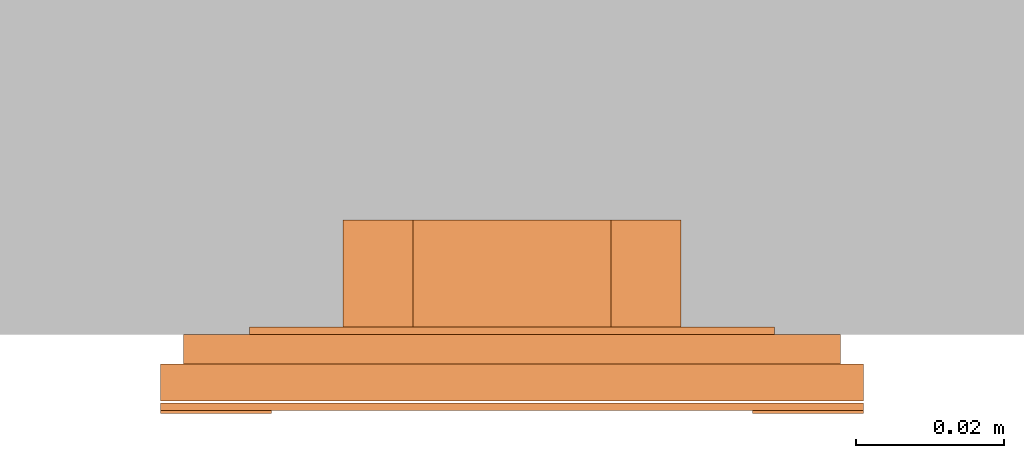
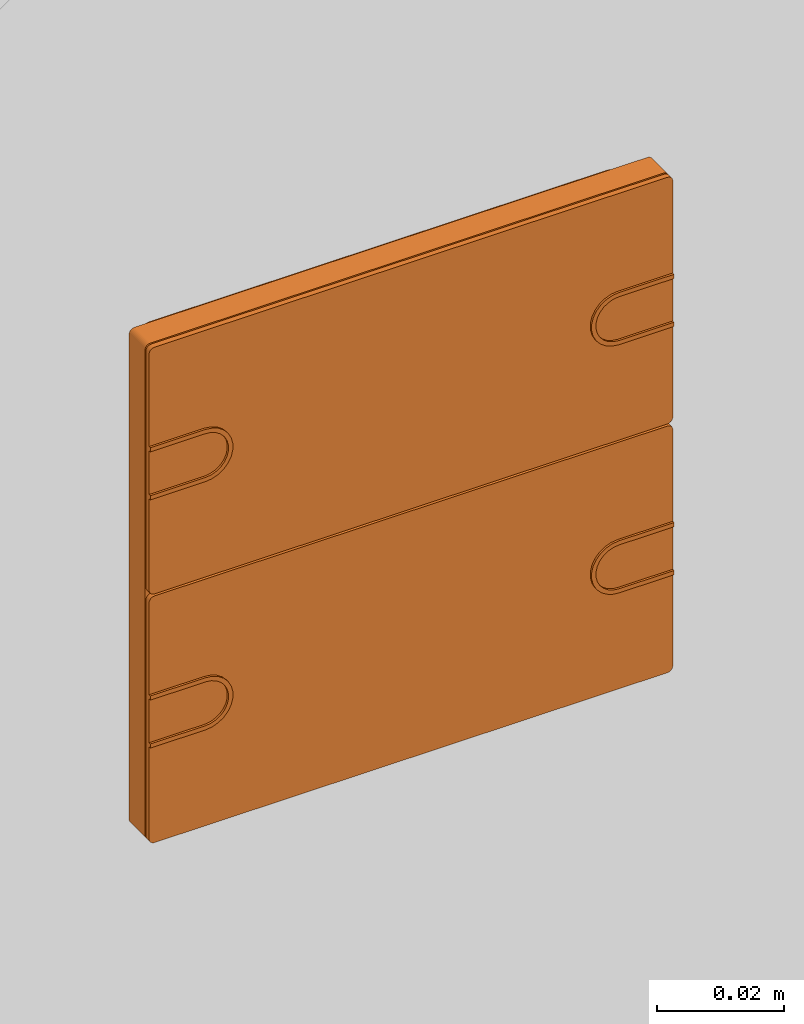
# One storey, part 2 of 2: 1 proxy.
"""IFC2X3 building model written with IfcOpenShell, lengths in metres."""

from ifc_helpers import new_model, entity, si_unit, converted_unit, derived_unit, direction, frame, frame_2d, origin, place, context, subcontext, project, spatial, polyline, circle_curve, parameter, trimmed, segment, composite_curve, outline, extrude, source, transform, mapped, material, type_object, type_shapes, element, save


model = new_model("IFC2X3")

# Units and contexts
model_context = context("Model", 3, precision=1e-05, world=origin(), true_north=direction((6.12303176911189e-17, 1.0)))
body_context = subcontext(model_context, "Body", "Model", "MODEL_VIEW")
ifc_project = project(units=[si_unit("LENGTHUNIT", "METRE"), si_unit("AREAUNIT", "SQUARE_METRE"), si_unit("VOLUMEUNIT", "CUBIC_METRE"), converted_unit("PLANEANGLEUNIT", "DEGREE", entity("IfcRatioMeasure", 0.0174532925199433), si_unit("PLANEANGLEUNIT", "RADIAN"), dimensions=[0, 0, 0, 0, 0, 0, 0]), si_unit("MASSUNIT", "GRAM", prefix="KILO"), si_unit("TIMEUNIT", "SECOND"), si_unit("FREQUENCYUNIT", "HERTZ"), si_unit("THERMODYNAMICTEMPERATUREUNIT", "DEGREE_CELSIUS"), derived_unit("THERMALTRANSMITTANCEUNIT", [(si_unit("MASSUNIT", "GRAM", prefix="KILO"), 1), (si_unit("THERMODYNAMICTEMPERATUREUNIT", "KELVIN"), -1), (si_unit("TIMEUNIT", "SECOND"), -3)]), derived_unit("VOLUMETRICFLOWRATEUNIT", [(si_unit("LENGTHUNIT", "METRE"), 3), (si_unit("TIMEUNIT", "SECOND"), -1)]), si_unit("ELECTRICCURRENTUNIT", "AMPERE"), si_unit("ELECTRICVOLTAGEUNIT", "VOLT"), si_unit("POWERUNIT", "WATT"), si_unit("FORCEUNIT", "NEWTON", prefix="KILO"), si_unit("ILLUMINANCEUNIT", "LUX"), si_unit("LUMINOUSFLUXUNIT", "LUMEN"), si_unit("LUMINOUSINTENSITYUNIT", "CANDELA"), derived_unit("USERDEFINED", [(si_unit("MASSUNIT", "GRAM", prefix="KILO"), -1), (si_unit("LENGTHUNIT", "METRE"), -2), (si_unit("TIMEUNIT", "SECOND"), 3), (si_unit("LUMINOUSFLUXUNIT", "LUMEN"), 1)]), derived_unit("LINEARVELOCITYUNIT", [(si_unit("LENGTHUNIT", "METRE"), 1), (si_unit("TIMEUNIT", "SECOND"), -1)]), si_unit("PRESSUREUNIT", "PASCAL"), derived_unit("USERDEFINED", [(si_unit("LENGTHUNIT", "METRE"), -2), (si_unit("MASSUNIT", "GRAM", prefix="KILO"), 1), (si_unit("TIMEUNIT", "SECOND"), -2)])], contexts=[model_context])

# Site, building, storey
site_placement = place(None, origin())
site = spatial("IfcSite", under=ifc_project, at=site_placement, CompositionType="ELEMENT")
building_placement = place(site_placement, origin())
building = spatial("IfcBuilding", under=site, at=building_placement, CompositionType="ELEMENT")
storey_placement = place(building_placement, origin())
storey = spatial("IfcBuildingStorey", under=building, at=storey_placement, Name="Ebene 0", CompositionType="ELEMENT", Elevation=0.0)

# Proxy
ifc_material = material(Name="White")
building_element_proxy_type = type_object("IfcBuildingElementProxyType", PredefinedType="NOTDEFINED", material=ifc_material)
shared_shape = source(origin(), body_context, "Body", "SweptSolid", [
    extrude(outline(composite_curve([segment(polyline([(-0.00499999999999999, -0.00499999999999998), (-0.0042, -0.00499999999999998)]), True, "CONTINUOUS"), segment(polyline([(-0.0042, -0.00499999999999998), (-0.00420000000000001, 0.00499999999999998)]), True, "CONTINUOUS"), segment(trimmed(circle_curve(frame_2d((0.0, 0.005), x_axis=(0.0, 1.0)), 0.00420000000000002), [parameter(270.0)], [parameter(90.0000000000005)], True, "PARAMETER"), False, "CONTINUOUS"), segment(polyline([(0.00420000000000002, 0.00500000000000003), (0.00420000000000001, -0.00499999999999998)]), True, "CONTINUOUS"), segment(polyline([(0.00420000000000001, -0.00499999999999998), (0.005, -0.00499999999999998)]), True, "CONTINUOUS"), segment(polyline([(0.005, -0.00499999999999998), (0.00500000000000001, 0.00500000000000003)]), True, "CONTINUOUS"), segment(trimmed(circle_curve(frame_2d((0.0, 0.005), x_axis=(0.0, 1.0)), 0.00500000000000001), [parameter(270.0)], [parameter(90.0000000000002)], True, "PARAMETER"), True, "CONTINUOUS"), segment(polyline([(-0.00500000000000002, 0.00499999999999998), (-0.00499999999999999, -0.00499999999999998)]), True, "CONTINUOUS")], self_intersect=False)), frame((-0.0424999999999937, 0.0237999992370521, 0.00949999999999813), z_axis=(0.0, 0.0, 1.0), x_axis=(0.0, -1.0, 0.0)), (0.0, 0.0, 1.0), 0.0012),
    extrude(outline(composite_curve([segment(polyline([(-0.00499999999999996, -0.00500000000000001), (0.005, -0.00500000000000001)]), True, "CONTINUOUS"), segment(trimmed(circle_curve(frame_2d((0.005, 0.0), x_axis=(1.0, 0.0)), 0.00500000000000001), [parameter(269.999999999999)], [parameter(89.9999999999998)], True, "PARAMETER"), True, "CONTINUOUS"), segment(polyline([(0.00500000000000002, 0.00500000000000002), (-0.00499999999999998, 0.00499999999999999)]), True, "CONTINUOUS"), segment(polyline([(-0.00499999999999998, 0.00499999999999999), (-0.00499999999999998, 0.0042)]), True, "CONTINUOUS"), segment(polyline([(-0.00499999999999998, 0.00419999999999999), (0.00500000000000003, 0.00420000000000003)]), True, "CONTINUOUS"), segment(trimmed(circle_curve(frame_2d((0.00500000000000001, 0.0), x_axis=(1.0, 0.0)), 0.00420000000000002), [parameter(270.0)], [parameter(90.0000000000002)], True, "PARAMETER"), False, "CONTINUOUS"), segment(polyline([(0.00499999999999999, -0.0042), (-0.00499999999999996, -0.00420000000000001)]), True, "CONTINUOUS"), segment(polyline([(-0.00499999999999996, -0.00420000000000001), (-0.00499999999999996, -0.00500000000000001)]), True, "CONTINUOUS")], self_intersect=False)), frame((-0.0424999999999937, -0.0237999992370689, 0.00949999999999813)), (0.0, 0.0, 1.0), 0.0012),
    extrude(outline(composite_curve([segment(polyline([(-0.00499999999999996, -0.005), (0.005, -0.00500000000000001)]), True, "CONTINUOUS"), segment(trimmed(circle_curve(frame_2d((0.005, 0.0), x_axis=(1.0, 0.0)), 0.00500000000000001), [parameter(269.999999999999)], [parameter(89.9999999999998)], True, "PARAMETER"), True, "CONTINUOUS"), segment(polyline([(0.00500000000000001, 0.00500000000000002), (-0.00499999999999998, 0.00499999999999998)]), True, "CONTINUOUS"), segment(polyline([(-0.00499999999999998, 0.00499999999999998), (-0.00499999999999998, 0.0042)]), True, "CONTINUOUS"), segment(polyline([(-0.00499999999999998, 0.00419999999999999), (0.00500000000000001, 0.00420000000000004)]), True, "CONTINUOUS"), segment(trimmed(circle_curve(frame_2d((0.00500000000000001, 0.0), x_axis=(1.0, 0.0)), 0.00420000000000002), [parameter(270.0)], [parameter(90.0000000000003)], True, "PARAMETER"), False, "CONTINUOUS"), segment(polyline([(0.00499999999999999, -0.0042), (-0.00499999999999996, -0.00420000000000001)]), True, "CONTINUOUS"), segment(polyline([(-0.00499999999999996, -0.00420000000000001), (-0.00499999999999996, -0.005)]), True, "CONTINUOUS")], self_intersect=False)), frame((0.0425000000000063, 0.0237999992370521, 0.00949999999999813), z_axis=(0.0, 0.0, 1.0), x_axis=(-1.0, 0.0, 0.0)), (0.0, 0.0, 1.0), 0.0012),
    extrude(outline(composite_curve([segment(polyline([(-0.005, -0.00499999999999998), (-0.0042, -0.00499999999999998)]), True, "CONTINUOUS"), segment(polyline([(-0.0042, -0.00499999999999998), (-0.00420000000000002, 0.00499999999999996)]), True, "CONTINUOUS"), segment(trimmed(circle_curve(frame_2d((0.0, 0.005), x_axis=(0.0, 1.0)), 0.00420000000000002), [parameter(270.0)], [parameter(90.0000000000005)], True, "PARAMETER"), False, "CONTINUOUS"), segment(polyline([(0.00420000000000002, 0.00500000000000001), (0.0042, -0.00499999999999998)]), True, "CONTINUOUS"), segment(polyline([(0.00420000000000001, -0.00499999999999998), (0.005, -0.00499999999999998)]), True, "CONTINUOUS"), segment(polyline([(0.005, -0.00499999999999998), (0.005, 0.00500000000000001)]), True, "CONTINUOUS"), segment(trimmed(circle_curve(frame_2d((0.0, 0.00499999999999998), x_axis=(0.0, 1.0)), 0.00500000000000001), [parameter(270.0)], [parameter(90.0000000000002)], True, "PARAMETER"), True, "CONTINUOUS"), segment(polyline([(-0.00500000000000002, 0.00499999999999998), (-0.005, -0.00499999999999998)]), True, "CONTINUOUS")], self_intersect=False)), frame((0.0425000000000063, -0.0237999992370689, 0.00949999999999813), z_axis=(0.0, 0.0, 1.0), x_axis=(0.0, 1.0, 0.0)), (0.0, 0.0, 1.0), 0.0012),
    extrude(outline(composite_curve([segment(trimmed(circle_curve(frame_2d((0.0465000000000126, 0.0226500000000084), x_axis=(1.0, 0.0)), 0.001), [parameter(0.0)], [parameter(90.0000000000001)], True, "PARAMETER"), True, "CONTINUOUS"), segment(polyline([(0.0465000000000126, 0.0236500000000084), (-0.0465000000000126, 0.0236500000000084)]), True, "CONTINUOUS"), segment(trimmed(circle_curve(frame_2d((-0.0465000000000126, 0.0226500000000084), x_axis=(1.0, 0.0)), 0.001), [parameter(90.0000000000011)], [parameter(179.999999999999)], True, "PARAMETER"), True, "CONTINUOUS"), segment(polyline([(-0.0475000000000126, 0.0226500000000085), (-0.0475000000000126, -0.0226500000000084)]), True, "CONTINUOUS"), segment(trimmed(circle_curve(frame_2d((-0.0465000000000126, -0.0226500000000084), x_axis=(1.0, 0.0)), 0.001), [parameter(180.0)], [parameter(269.999999999999)], True, "PARAMETER"), True, "CONTINUOUS"), segment(polyline([(-0.0465000000000126, -0.0236500000000084), (0.0465000000000126, -0.0236500000000084)]), True, "CONTINUOUS"), segment(trimmed(circle_curve(frame_2d((0.0465000000000125, -0.0226500000000084), x_axis=(1.0, 0.0)), 0.001), [parameter(269.999999999999)], [parameter(359.999999999999)], True, "PARAMETER"), True, "CONTINUOUS"), segment(polyline([(0.0475000000000125, -0.0226500000000084), (0.0475000000000127, 0.0226500000000085)]), True, "CONTINUOUS")], self_intersect=False)), frame((0.0, 0.0238499999999831, 0.00929999999999813)), (0.0, 0.0, 1.0), 0.001),
    extrude(outline(composite_curve([segment(trimmed(circle_curve(frame_2d((-0.0465000000000125, 0.0226500000000083), x_axis=(1.0, 0.0)), 0.001), [parameter(90.0000000000003)], [parameter(180.0)], True, "PARAMETER"), True, "CONTINUOUS"), segment(polyline([(-0.0475000000000125, 0.0226500000000083), (-0.0475000000000125, -0.0226500000000085)]), True, "CONTINUOUS"), segment(trimmed(circle_curve(frame_2d((-0.0465000000000125, -0.0226500000000085), x_axis=(-1.0, 0.0)), 0.001), [parameter(2.54444374517082e-13)], [parameter(90.0000000000001)], True, "PARAMETER"), True, "CONTINUOUS"), segment(polyline([(-0.0465000000000125, -0.0236500000000085), (0.0465000000000126, -0.0236500000000082)]), True, "CONTINUOUS"), segment(trimmed(circle_curve(frame_2d((0.0465000000000126, -0.0226500000000082), x_axis=(-1.0, 0.0)), 0.001), [parameter(90.0000000000001)], [parameter(180.0)], True, "PARAMETER"), True, "CONTINUOUS"), segment(polyline([(0.0475000000000126, -0.0226500000000082), (0.0475000000000124, 0.0226500000000083)]), True, "CONTINUOUS"), segment(trimmed(circle_curve(frame_2d((0.0465000000000124, 0.0226500000000083), x_axis=(-1.0, 0.0)), 0.001), [parameter(180.0)], [parameter(269.999999999999)], True, "PARAMETER"), True, "CONTINUOUS"), segment(polyline([(0.0465000000000125, 0.0236500000000083), (-0.0465000000000125, 0.0236500000000083)]), True, "CONTINUOUS")], self_intersect=False)), frame((0.0, -0.0238500000000336, 0.00929999999999813), z_axis=(0.0, 0.0, 1.0), x_axis=(-1.0, 0.0, 0.0)), (0.0, 0.0, 1.0), 0.001),
    extrude(outline(composite_curve([segment(trimmed(circle_curve(frame_2d((-0.0465000000000125, 0.0465000000000168), x_axis=(1.0, 0.0)), 0.001), [parameter(90.0000000000003)], [parameter(180.0)], True, "PARAMETER"), True, "CONTINUOUS"), segment(polyline([(-0.0475000000000125, 0.0465000000000168), (-0.0475000000000125, -0.0465000000000169)]), True, "CONTINUOUS"), segment(trimmed(circle_curve(frame_2d((-0.0465000000000125, -0.0465000000000169), x_axis=(-1.0, 0.0)), 0.001), [parameter(0.0)], [parameter(90.0000000000001)], True, "PARAMETER"), True, "CONTINUOUS"), segment(polyline([(-0.0465000000000125, -0.0475000000000169), (0.0465000000000127, -0.0475000000000166)]), True, "CONTINUOUS"), segment(trimmed(circle_curve(frame_2d((0.0465000000000127, -0.0465000000000166), x_axis=(-1.0, 0.0)), 0.001), [parameter(90.0000000000011)], [parameter(179.999999999999)], True, "PARAMETER"), True, "CONTINUOUS"), segment(polyline([(0.0475000000000127, -0.0465000000000166), (0.0475000000000124, 0.0465000000000168)]), True, "CONTINUOUS"), segment(trimmed(circle_curve(frame_2d((0.0465000000000124, 0.0465000000000168), x_axis=(-1.0, 0.0)), 0.001), [parameter(180.0)], [parameter(269.999999999999)], True, "PARAMETER"), True, "CONTINUOUS"), segment(polyline([(0.0465000000000124, 0.0475000000000168), (-0.0465000000000125, 0.0475000000000168)]), True, "CONTINUOUS")], self_intersect=False)), frame((0.0, 0.0, 0.00399999999999813), z_axis=(0.0, 0.0, 1.0), x_axis=(-1.0, 0.0, 0.0)), (0.0, 0.0, 1.0), 0.005),
    extrude(outline(composite_curve([segment(polyline([(-0.0413999999999997, -0.0443999999999999), (0.0414, -0.0443999999999999)]), True, "CONTINUOUS"), segment(trimmed(circle_curve(frame_2d((0.0414, -0.0413999999999999), x_axis=(-1.0, 0.0)), 0.003), [parameter(89.9999999999998)], [parameter(180.0)], True, "PARAMETER"), True, "CONTINUOUS"), segment(polyline([(0.0444, -0.0413999999999999), (0.0444, 0.0414000000000002)]), True, "CONTINUOUS"), segment(trimmed(circle_curve(frame_2d((0.0414, 0.0414000000000001), x_axis=(-1.0, 0.0)), 0.003), [parameter(180.0)], [parameter(270.0)], True, "PARAMETER"), True, "CONTINUOUS"), segment(polyline([(0.0414, 0.0444000000000001), (-0.0414000000000003, 0.0443999999999996)]), True, "CONTINUOUS"), segment(trimmed(circle_curve(frame_2d((-0.0414000000000003, 0.0413999999999996), x_axis=(-1.0, 0.0)), 0.003), [parameter(270.0)], [parameter(1.52666624710249e-13)], True, "PARAMETER"), True, "CONTINUOUS"), segment(polyline([(-0.0444000000000003, 0.0413999999999996), (-0.0443999999999997, -0.0413999999999999)]), True, "CONTINUOUS"), segment(trimmed(circle_curve(frame_2d((-0.0413999999999997, -0.0413999999999999), x_axis=(-1.0, 0.0)), 0.003), [parameter(0.0)], [parameter(89.9999999999998)], True, "PARAMETER"), True, "CONTINUOUS")], self_intersect=False), holes=[composite_curve([segment(trimmed(circle_curve(frame_2d((0.0414, 0.0414000000000001), x_axis=(-1.0, 0.0)), 0.001), [parameter(180.000000000001)], [parameter(270.0)], True, "PARAMETER"), False, "CONTINUOUS"), segment(polyline([(0.0424, 0.0414000000000001), (0.0424, -0.0413999999999999)]), True, "CONTINUOUS"), segment(trimmed(circle_curve(frame_2d((0.0414, -0.0413999999999999), x_axis=(-1.0, 0.0)), 0.001), [parameter(90.0000000000005)], [parameter(180.0)], True, "PARAMETER"), False, "CONTINUOUS"), segment(polyline([(0.0414, -0.0423999999999999), (-0.0413999999999997, -0.0423999999999999)]), True, "CONTINUOUS"), segment(trimmed(circle_curve(frame_2d((-0.0413999999999997, -0.0413999999999999), x_axis=(-1.0, 0.0)), 0.001), [parameter(5.08888749034163e-13)], [parameter(90.0000000000001)], True, "PARAMETER"), False, "CONTINUOUS"), segment(polyline([(-0.0423999999999997, -0.0413999999999999), (-0.0424000000000003, 0.0413999999999996)]), True, "CONTINUOUS"), segment(trimmed(circle_curve(frame_2d((-0.0414000000000003, 0.0413999999999996), x_axis=(-1.0, 0.0)), 0.001), [parameter(270.0)], [parameter(5.08888749034163e-13)], True, "PARAMETER"), False, "CONTINUOUS"), segment(polyline([(-0.0414000000000003, 0.0423999999999996), (0.0414, 0.0424000000000001)]), True, "CONTINUOUS")], self_intersect=False)]), frame((0.0, 0.0, 0.0), z_axis=(0.0, 0.0, 1.0), x_axis=(-1.0, 0.0, 0.0)), (0.0, 0.0, 1.0), 0.004),
    extrude(outline(composite_curve([segment(trimmed(circle_curve(frame_2d((-0.02545, 0.02545), x_axis=(1.0, 0.0)), 0.01), [parameter(90.0000000000001)], [parameter(180.0)], True, "PARAMETER"), True, "CONTINUOUS"), segment(polyline([(-0.03545, 0.0254500000000001), (-0.03545, -0.0254500000000001)]), True, "CONTINUOUS"), segment(trimmed(circle_curve(frame_2d((-0.02545, -0.02545), x_axis=(1.0, 0.0)), 0.01), [parameter(180.0)], [parameter(270.0)], True, "PARAMETER"), True, "CONTINUOUS"), segment(polyline([(-0.0254500000000001, -0.03545), (0.02545, -0.03545)]), True, "CONTINUOUS"), segment(trimmed(circle_curve(frame_2d((0.02545, -0.02545), x_axis=(-1.0, 0.0)), 0.01), [parameter(90.0000000000001)], [parameter(180.0)], True, "PARAMETER"), True, "CONTINUOUS"), segment(polyline([(0.03545, -0.02545), (0.03545, 0.02545)]), True, "CONTINUOUS"), segment(trimmed(circle_curve(frame_2d((0.02545, 0.02545), x_axis=(-1.0, 0.0)), 0.01), [parameter(180.0)], [parameter(270.0)], True, "PARAMETER"), True, "CONTINUOUS"), segment(polyline([(0.0254500000000001, 0.03545), (-0.0254500000000001, 0.03545)]), True, "CONTINUOUS")], self_intersect=False), holes=[composite_curve([segment(trimmed(circle_curve(frame_2d((-0.0270821897194447, 0.0299106168441909), x_axis=(1.0, 0.0)), 0.00200000000000001), [parameter(315.0)], [parameter(135.0)], True, "PARAMETER"), False, "CONTINUOUS"), segment(polyline([(-0.0256679761570716, 0.0284964032818178), (-0.0284964032818178, 0.0256679761570716)]), True, "CONTINUOUS"), segment(trimmed(circle_curve(frame_2d((-0.0299106168441909, 0.0270821897194447), x_axis=(1.0, 0.0)), 0.002), [parameter(135.000000000001)], [parameter(315.0)], True, "PARAMETER"), False, "CONTINUOUS"), segment(polyline([(-0.031324830406564, 0.0284964032818178), (-0.0284964032818178, 0.031324830406564)]), True, "CONTINUOUS")], self_intersect=False), composite_curve([segment(trimmed(circle_curve(frame_2d((-0.0299106168440928, -0.0270821897195872), x_axis=(0.0, 1.0)), 0.00200000000000001), [parameter(315.0)], [parameter(135.000000000001)], True, "PARAMETER"), False, "CONTINUOUS"), segment(polyline([(-0.0284964032817251, -0.0256679761572088), (-0.0256679761569682, -0.0284964032819443)]), True, "CONTINUOUS"), segment(trimmed(circle_curve(frame_2d((-0.0270821897193359, -0.0299106168443227), x_axis=(0.0, 1.0)), 0.002), [parameter(135.0)], [parameter(315.0)], True, "PARAMETER"), False, "CONTINUOUS"), segment(polyline([(-0.0284964032817037, -0.0313248304067012), (-0.0313248304064606, -0.0284964032819657)]), True, "CONTINUOUS")], self_intersect=False), composite_curve([segment(polyline([(0.0284964032818178, 0.031324830406564), (0.031324830406564, 0.0284964032818178)]), True, "CONTINUOUS"), segment(trimmed(circle_curve(frame_2d((0.0299106168441909, 0.0270821897194447), x_axis=(-1.0, 0.0)), 0.002), [parameter(45.0000000000004)], [parameter(225.0)], True, "PARAMETER"), False, "CONTINUOUS"), segment(polyline([(0.0284964032818178, 0.0256679761570716), (0.0256679761570716, 0.0284964032818178)]), True, "CONTINUOUS"), segment(trimmed(circle_curve(frame_2d((0.0270821897194447, 0.0299106168441909), x_axis=(-1.0, 0.0)), 0.00200000000000001), [parameter(225.0)], [parameter(44.9999999999999)], True, "PARAMETER"), False, "CONTINUOUS")], self_intersect=False), composite_curve([segment(polyline([(0.0313248304064606, -0.0284964032819657), (0.0284964032817037, -0.0313248304067012)]), True, "CONTINUOUS"), segment(trimmed(circle_curve(frame_2d((0.0270821897193359, -0.0299106168443227), x_axis=(0.0, 1.0)), 0.002), [parameter(45.0000000000003)], [parameter(225.0)], True, "PARAMETER"), False, "CONTINUOUS"), segment(polyline([(0.0256679761569682, -0.0284964032819443), (0.0284964032817251, -0.0256679761572088)]), True, "CONTINUOUS"), segment(trimmed(circle_curve(frame_2d((0.0299106168440928, -0.0270821897195872), x_axis=(0.0, 1.0)), 0.00200000000000001), [parameter(225.0)], [parameter(45.0)], True, "PARAMETER"), False, "CONTINUOUS")], self_intersect=False), polyline([(0.0133901883561006, 0.022831011754894), (0.022831011754894, 0.0133901883561005), (0.022831011754894, -0.0133901883561007), (0.0133901883561006, -0.022831011754894), (-0.0133901883561006, -0.022831011754894), (-0.022831011754894, -0.0133901883561006), (-0.022831011754894, 0.0133901883561006), (-0.0133901883561006, 0.022831011754894), (0.0133901883561006, 0.022831011754894)]), composite_curve([segment(trimmed(circle_curve(frame_2d((-0.00377680189852487, 0.029788004180913), x_axis=(1.0, 0.0)), 0.0029), [parameter(43.7312395648615)], [parameter(324.455810783523)], True, "PARAMETER"), False, "CONTINUOUS"), segment(trimmed(circle_curve(frame_2d((0.00020313886723953, 0.00221282045422128), x_axis=(1.0, 0.0)), 0.0296398498895369), [parameter(78.5704662642775)], [parameter(93.645183270812)], True, "PARAMETER"), False, "CONTINUOUS"), segment(trimmed(circle_curve(frame_2d((0.0057098792346926, 0.0294507398536438), x_axis=(1.0, 0.0)), 0.0018508512986561), [parameter(270.948014931406)], [parameter(78.5704662642829)], True, "PARAMETER"), False, "CONTINUOUS"), segment(trimmed(circle_curve(frame_2d((0.000198292327786931, -0.000143073394859841), x_axis=(1.0, 0.0)), 0.0282913782444803), [parameter(78.7028434483939)], [parameter(93.2734120855582)], True, "PARAMETER"), True, "CONTINUOUS")], self_intersect=False), composite_curve([segment(trimmed(circle_curve(frame_2d((0.00377680189854983, -0.0297880041809467), x_axis=(-1.0, 0.0)), 0.0029), [parameter(43.7312395648614)], [parameter(324.455810783523)], True, "PARAMETER"), False, "CONTINUOUS"), segment(trimmed(circle_curve(frame_2d((-0.000203138867214483, -0.00221282045425497), x_axis=(-1.0, 0.0)), 0.0296398498895369), [parameter(78.5704662642775)], [parameter(93.645183270812)], True, "PARAMETER"), False, "CONTINUOUS"), segment(trimmed(circle_curve(frame_2d((-0.00570987923466764, -0.0294507398536775), x_axis=(-1.0, 0.0)), 0.0018508512986561), [parameter(270.948014931407)], [parameter(78.5704662642829)], True, "PARAMETER"), False, "CONTINUOUS"), segment(trimmed(circle_curve(frame_2d((-0.000198292327761875, 0.000143073394826152), x_axis=(-1.0, 0.0)), 0.0282913782444803), [parameter(78.7028434483939)], [parameter(93.2734120855582)], True, "PARAMETER"), True, "CONTINUOUS")], self_intersect=False), composite_curve([segment(trimmed(circle_curve(frame_2d((-0.0297880041809172, -0.00377680189855411), x_axis=(0.0, 1.0)), 0.0029), [parameter(43.7312395648614)], [parameter(324.455810783523)], True, "PARAMETER"), False, "CONTINUOUS"), segment(trimmed(circle_curve(frame_2d((-0.00221282045422552, 0.00020313886721024), x_axis=(0.0, 1.0)), 0.0296398498895369), [parameter(78.5704662642775)], [parameter(93.645183270812)], True, "PARAMETER"), False, "CONTINUOUS"), segment(trimmed(circle_curve(frame_2d((-0.0294507398536481, 0.00570987923466336), x_axis=(0.0, 1.0)), 0.0018508512986561), [parameter(270.948014931407)], [parameter(78.5704662642829)], True, "PARAMETER"), False, "CONTINUOUS"), segment(trimmed(circle_curve(frame_2d((0.000143073394855601, 0.000198292327757636), x_axis=(0.0, 1.0)), 0.0282913782444803), [parameter(78.702843448394)], [parameter(93.2734120855582)], True, "PARAMETER"), True, "CONTINUOUS")], self_intersect=False), composite_curve([segment(trimmed(circle_curve(frame_2d((0.0297880041809424, 0.00377680189852048), x_axis=(0.0, -1.0)), 0.0029), [parameter(43.7312395648607)], [parameter(324.455810783523)], True, "PARAMETER"), False, "CONTINUOUS"), segment(trimmed(circle_curve(frame_2d((0.00221282045425073, -0.000203138867243781), x_axis=(0.0, -1.0)), 0.0296398498895369), [parameter(78.5704662642775)], [parameter(93.645183270812)], True, "PARAMETER"), False, "CONTINUOUS"), segment(trimmed(circle_curve(frame_2d((0.0294507398536733, -0.00570987923469698), x_axis=(0.0, -1.0)), 0.0018508512986561), [parameter(270.948014931407)], [parameter(78.5704662642836)], True, "PARAMETER"), False, "CONTINUOUS"), segment(trimmed(circle_curve(frame_2d((-0.000143073394830393, -0.000198292327791169), x_axis=(0.0, -1.0)), 0.0282913782444803), [parameter(78.702843448394)], [parameter(93.2734120855582)], True, "PARAMETER"), True, "CONTINUOUS")], self_intersect=False)]), frame((0.0, 0.0, -0.00100000000000187)), (0.0, 0.0, 1.0), 0.001),
    extrude(outline(polyline([(-0.00667567024527144, -0.0256122562211992), (0.00667567024527142, -0.0256122562211992), (0.0256122562211992, -0.00667567024527147), (0.0256122562211992, 0.00667567024527142), (0.00667567024527143, 0.0256122562211992), (-0.00667567024527141, 0.0256122562211992), (-0.0256122562211992, 0.00667567024527147), (-0.0256122562211992, -0.00667567024527143), (-0.00667567024527144, -0.0256122562211992)])), frame((0.0, 0.0, -0.0155000000000019), z_axis=(0.0, 0.0, 1.0), x_axis=(-0.707106781186548, -0.707106781186547, 0.0)), (0.0, 0.0, 1.0), 0.0155),
])
type_shapes(building_element_proxy_type, [shared_shape])
proxy_placement = place(storey_placement, frame((-7.3192018927039, -2.38240134987377, 1.5033188798966), z_axis=(0.0, -1.0, 0.0), x_axis=(1.0, 0.0, 0.0)))
element("IfcBuildingElementProxy", 1, at=proxy_placement, inside=storey, type_object=building_element_proxy_type, material=ifc_material, context=body_context, shape_type="MappedRepresentation", body=[
    mapped(shared_shape, transform((0.0, 0.0, 0.0), scale=1.0)),
])

save(model, "model.ifc")
